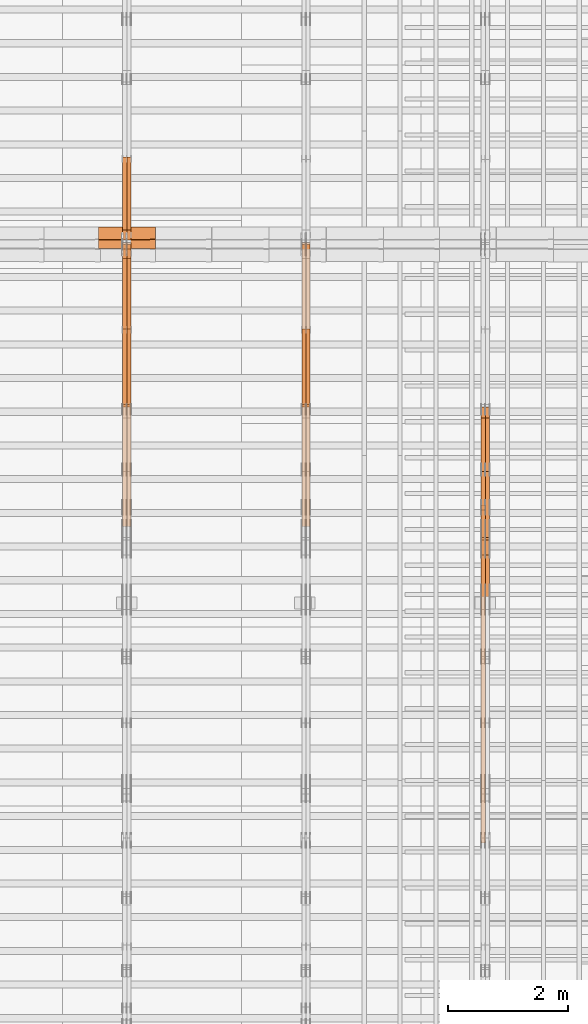
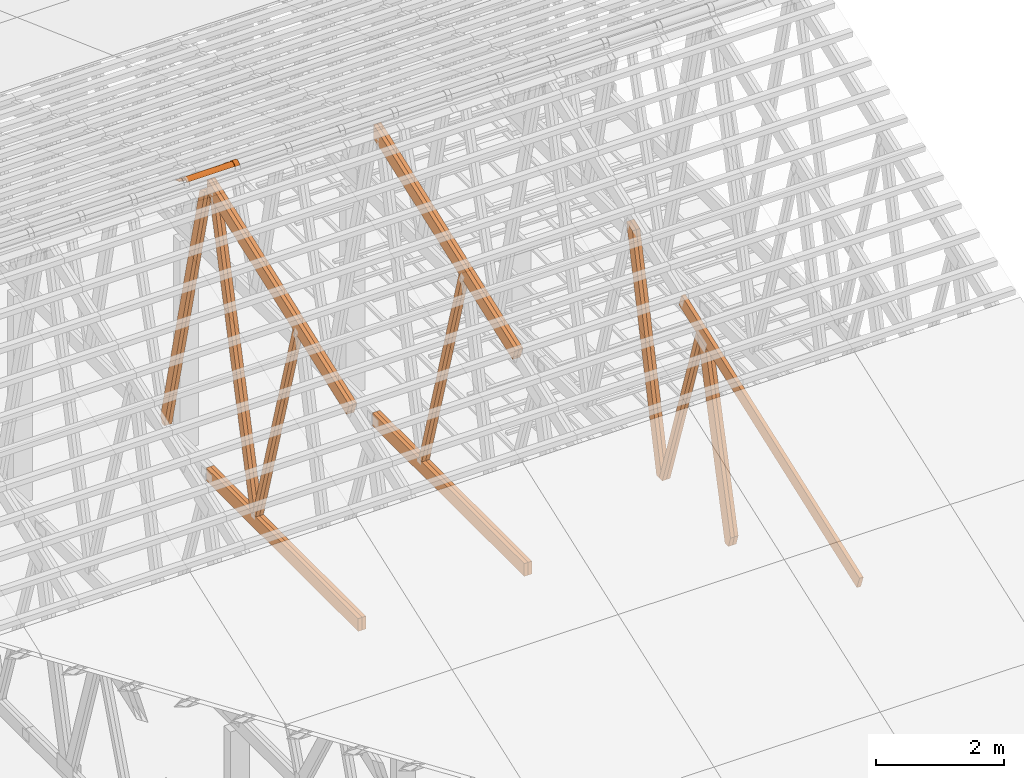
# One storey, part 52 of 189: 24 proxies.
"""IFC2X3 building model written with IfcOpenShell, lengths in millimetres."""

import ifcopenshell
import ifcopenshell.guid

model = None  # the IFC model being written
_history = None  # IfcOwnerHistory: only IFC2X3 demands one
_inside = {}  # id of a spatial element -> (the spatial element, [elements in it])
_under = {}  # id of a project, library or spatial element -> (it, [spatial elements below it])
_declared = {}  # id of a project -> (the project, [libraries it declares])
_typed = {}  # id of a type object -> (the type object, [elements of that type])
_made_of = {}  # id of a material, layer set ... -> (it, [elements and type objects made of it])


def new_model(schema):
    """Start an empty IFC model of exactly this schema.

    Asked for "IFC4X3", IfcOpenShell would pick the latest addendum, in which some entities
    have other attributes; the version numbers below select the first issue.
    IFC2X3 requires an IfcOwnerHistory on every rooted entity: one is made here for all.
    """
    global model, _history
    if schema == "IFC4X3":
        model = ifcopenshell.file(schema_version=(4, 3, 0, 0))
    else:
        model = ifcopenshell.file(schema=schema)
    _inside.clear()
    _under.clear()
    _declared.clear()
    _typed.clear()
    _made_of.clear()
    _history = None
    if model.schema == "IFC2X3":
        org = make("IfcOrganization", Name="unknown")
        user = make(
            "IfcPersonAndOrganization",
            ThePerson=make("IfcPerson", FamilyName="unknown"),
            TheOrganization=org,
        )
        app = make(
            "IfcApplication",
            ApplicationDeveloper=org,
            Version="unknown",
            ApplicationFullName="unknown",
            ApplicationIdentifier="unknown",
        )
        _history = make(
            "IfcOwnerHistory",
            OwningUser=user,
            OwningApplication=app,
            ChangeAction="ADDED",
            CreationDate=0,
        )
    return model


def make(cls, **values):
    """One entity of the class cls with the attributes given. An attribute that is None is left unset."""
    return model.create_entity(
        cls, **{name: value for name, value in values.items() if value is not None}
    )


def entity(cls, *values):
    """Any entity or typed value of the class cls, its attributes in the order of the schema. None: left unset."""
    e = model.create_entity(cls)
    for i, value in enumerate(values):
        if value is not None:
            e[i] = value
    return e


def rooted(cls, **values):
    """An entity with a GlobalId (a new one), such as an element, a storey or a relation."""
    return make(cls, GlobalId=ifcopenshell.guid.new(), OwnerHistory=_history, **values)


def si_unit(unit_type, name, prefix=None):
    """IfcSIUnit, for example si_unit("LENGTHUNIT", "METRE", prefix="MILLI")."""
    return make("IfcSIUnit", UnitType=unit_type, Prefix=prefix, Name=name)


def converted_unit(unit_type, name, factor, base, dimensions=None, offset=None):
    """IfcConversionBasedUnit, such as the inch: factor (a typed value) times the base unit."""
    return make(
        "IfcConversionBasedUnit"
        if offset is None
        else "IfcConversionBasedUnitWithOffset",
        ConversionOffset=offset,
        Dimensions=None
        if dimensions is None
        else entity("IfcDimensionalExponents", *dimensions),
        UnitType=unit_type,
        Name=name,
        ConversionFactor=make(
            "IfcMeasureWithUnit", ValueComponent=factor, UnitComponent=base
        ),
    )


def derived_unit(unit_type, elements):
    """IfcDerivedUnit: a product of units, each with its exponent."""
    return make(
        "IfcDerivedUnit",
        Elements=[
            make("IfcDerivedUnitElement", Unit=unit, Exponent=power)
            for unit, power in elements
        ],
        UnitType=unit_type,
    )


def assignment(units):
    """IfcUnitAssignment: the units of a project."""
    return None if units is None else make("IfcUnitAssignment", Units=units)


def point(xyz):
    """IfcCartesianPoint."""
    return None if xyz is None else make("IfcCartesianPoint", Coordinates=xyz)


def direction(xyz):
    """IfcDirection."""
    return None if xyz is None else make("IfcDirection", DirectionRatios=xyz)


def frame(location, z_axis=None, x_axis=None):
    """IfcAxis2Placement3D, a coordinate frame: its origin and axes. An axis left out is left unset."""
    return make(
        "IfcAxis2Placement3D",
        Location=point(location),
        Axis=direction(z_axis),
        RefDirection=direction(x_axis),
    )


def frame_2d(location, x_axis=None):
    """IfcAxis2Placement2D, a coordinate frame in the plane: its origin and x axis."""
    return make(
        "IfcAxis2Placement2D", Location=point(location), RefDirection=direction(x_axis)
    )


def origin():
    """The frame at (0, 0, 0) with its axes left unset."""
    return frame((0.0, 0.0, 0.0))


def origin_2d_with_axis():
    """The frame at (0, 0) in the plane with the x axis (1, 0) written out."""
    return frame_2d((0.0, 0.0), x_axis=(1.0, 0.0))


def place(relative_to, where):
    """IfcLocalPlacement: puts the frame where relative to a parent placement (None: the world)."""
    return make(
        "IfcLocalPlacement", PlacementRelTo=relative_to, RelativePlacement=where
    )


def context(
    kind, dimensions, precision=None, world=None, true_north=None, identifier=None
):
    """IfcGeometricRepresentationContext, for example the 3D "Model" context."""
    return make(
        "IfcGeometricRepresentationContext",
        ContextIdentifier=identifier,
        ContextType=kind,
        CoordinateSpaceDimension=dimensions,
        Precision=precision,
        WorldCoordinateSystem=world,
        TrueNorth=true_north,
    )


def subcontext(parent, identifier, kind, view, scale=None):
    """IfcGeometricRepresentationSubContext, for example "Body" below "Model"."""
    return make(
        "IfcGeometricRepresentationSubContext",
        ContextIdentifier=identifier,
        ContextType=kind,
        ParentContext=parent,
        TargetScale=scale,
        TargetView=view,
    )


def project(units=None, contexts=None):
    """IfcProject with its units and contexts."""
    return rooted(
        "IfcProject",
        Name="project",
        RepresentationContexts=contexts,
        UnitsInContext=assignment(units),
    )


def spatial(cls, under=None, at=None, **own):
    """A site, building, storey or space (cls), placed at a placement, below another one or the project."""
    s = rooted(cls, ObjectPlacement=at, **own)
    if under is not None:
        _under.setdefault(under.id(), (under, []))[1].append(s)
    return s


def polyline(points):
    """IfcPolyline through the points."""
    return make("IfcPolyline", Points=[point(p) for p in points])


def circle_curve(where, radius):
    """IfcCircle in the frame where."""
    return make("IfcCircle", Position=where, Radius=radius)


def parameter(value):
    """IfcParameterValue: where a trimmed curve begins or ends, as a parameter of its basis curve."""
    return model.create_entity("IfcParameterValue", value)


def trimmed(basis, trim1, trim2, sense, master):
    """IfcTrimmedCurve: the piece of a basis curve between two trims."""
    return make(
        "IfcTrimmedCurve",
        BasisCurve=basis,
        Trim1=trim1,
        Trim2=trim2,
        SenseAgreement=sense,
        MasterRepresentation=master,
    )


def segment(curve, same_sense, transition):
    """IfcCompositeCurveSegment."""
    return make(
        "IfcCompositeCurveSegment",
        Transition=transition,
        SameSense=same_sense,
        ParentCurve=curve,
    )


def composite_curve(segments, self_intersect=None):
    """IfcCompositeCurve: segments joined end to end."""
    return make("IfcCompositeCurve", Segments=segments, SelfIntersect=self_intersect)


def profile(cls, at=None, kind="AREA", **sizes):
    """A parametric profile (cls). Its sizes go by their IFC names, for example OverallWidth=200.0."""
    return make(cls, ProfileType=kind, Position=at, **sizes)


def rectangle(**sizes):
    """IfcRectangleProfileDef."""
    return profile("IfcRectangleProfileDef", **sizes)


def outline(outer, holes=None, kind="AREA"):
    """IfcArbitraryClosedProfileDef: a profile drawn as a closed curve; with holes, ...WithVoids."""
    if holes is None:
        return make("IfcArbitraryClosedProfileDef", ProfileType=kind, OuterCurve=outer)
    return make(
        "IfcArbitraryProfileDefWithVoids",
        ProfileType=kind,
        OuterCurve=outer,
        InnerCurves=holes,
    )


def extrude(swept, where, along, depth):
    """IfcExtrudedAreaSolid: the profile swept, set in the frame where, extruded along a direction by depth."""
    return make(
        "IfcExtrudedAreaSolid",
        SweptArea=swept,
        Position=where,
        ExtrudedDirection=direction(along),
        Depth=depth,
    )


def shape(context_of_items, identifier, shape_type, items):
    """IfcShapeRepresentation: the items that make up one representation, for example the "Body"."""
    return make(
        "IfcShapeRepresentation",
        ContextOfItems=context_of_items,
        RepresentationIdentifier=identifier,
        RepresentationType=shape_type,
        Items=items,
    )


def source(mapping_origin, context_of_items, identifier, shape_type, items):
    """IfcRepresentationMap: a shape defined once, which mapped items show again and again."""
    return make(
        "IfcRepresentationMap",
        MappingOrigin=mapping_origin,
        MappedRepresentation=shape(context_of_items, identifier, shape_type, items),
    )


def transform(
    local_origin,
    x_axis=None,
    y_axis=None,
    z_axis=None,
    scale=None,
    scale2=None,
    scale3=None,
    uniform=True,
):
    """IfcCartesianTransformationOperator3D, or its non-uniform kind. x_axis, y_axis, z_axis: its Axis1, 2, 3."""
    if uniform:
        return make(
            "IfcCartesianTransformationOperator3D",
            Axis1=direction(x_axis),
            Axis2=direction(y_axis),
            LocalOrigin=point(local_origin),
            Scale=scale,
            Axis3=direction(z_axis),
        )
    return make(
        "IfcCartesianTransformationOperator3DnonUniform",
        Axis1=direction(x_axis),
        Axis2=direction(y_axis),
        LocalOrigin=point(local_origin),
        Scale=scale,
        Axis3=direction(z_axis),
        Scale2=scale2,
        Scale3=scale3,
    )


def mapped(mapping_source, mapping_target):
    """IfcMappedItem: shows the shape of a source again, moved by a transform."""
    return make(
        "IfcMappedItem", MappingSource=mapping_source, MappingTarget=mapping_target
    )


def material(Name=None, Category=None):
    """IfcMaterial."""
    return make("IfcMaterial", Name=Name, Category=Category)


def made_of(thing, what):
    """Note that an element or type object is made of a material, layer set ...; save() writes the relation."""
    if what is not None:
        _made_of.setdefault(what.id(), (what, []))[1].append(thing)
    return thing


def type_object(cls, material=None, **own):
    """A type object (cls), such as IfcWallType, which elements share."""
    return made_of(rooted(cls, **own), material)


def type_shapes(of_type, sources):
    """Give a type object the sources (RepresentationMaps) that its elements show as mapped items."""
    of_type.RepresentationMaps = sources


def element(
    cls,
    number,
    at=None,
    inside=None,
    cuts=None,
    type_object=None,
    material=None,
    context=None,
    identifier="Body",
    shape_type=None,
    held_by="IfcProductDefinitionShape",
    body=None,
    shapes=None,
    **own,
):
    """One element of the class cls, such as IfcWall. Its Tag is "e" and its number.

    at: its placement. inside: the storey or other place that contains it. cuts: it is an
    opening in that element (IfcRelVoidsElement). A single representation is given by context,
    identifier, shape_type and body (its items); several are given by shapes. held_by: the class
    of the entity that holds the representations. save() writes the other relations.
    """
    e = rooted(cls, Tag="e%d" % number, ObjectPlacement=at, **own)
    if body is not None:
        shapes = [shape(context, identifier, shape_type, body)]
    if shapes is not None:
        e.Representation = make(held_by, Representations=shapes)
    if inside is not None:
        _inside.setdefault(inside.id(), (inside, []))[1].append(e)
    if cuts is not None:
        rooted(
            "IfcRelVoidsElement", RelatingBuildingElement=cuts, RelatedOpeningElement=e
        )
    if type_object is not None:
        _typed.setdefault(type_object.id(), (type_object, []))[1].append(e)
    return made_of(e, material)


def aggregate(whole, parts):
    """IfcRelAggregates: a whole, such as a stair, and the parts it consists of."""
    return rooted("IfcRelAggregates", RelatingObject=whole, RelatedObjects=parts)


def save(model, path):
    """Write the relations noted so far, then the file.

    IfcRelAggregates (storeys below a building ...), IfcRelContainedInSpatialStructure (elements
    in a storey), IfcRelDefinesByType, IfcRelAssociatesMaterial and IfcRelDeclares: one each for
    every whole, place, type object, material and project.
    """
    for whole, parts in _under.values():
        aggregate(whole, parts)
    for where, things in _inside.values():
        rooted(
            "IfcRelContainedInSpatialStructure",
            RelatedElements=things,
            RelatingStructure=where,
        )
    for kind, things in _typed.values():
        rooted("IfcRelDefinesByType", RelatedObjects=things, RelatingType=kind)
    for what, things in _made_of.values():
        rooted("IfcRelAssociatesMaterial", RelatedObjects=things, RelatingMaterial=what)
    for by, libraries in _declared.values():
        rooted("IfcRelDeclares", RelatingContext=by, RelatedDefinitions=libraries)
    model.write(path)


model = new_model("IFC2X3")

# Units and contexts
model_context = context("Model", 3, precision=0.01, world=origin(), true_north=direction((6.12303176911189e-17, 1.0)))
body_context = subcontext(model_context, "Body", "Model", "MODEL_VIEW")
ifc_project = project(units=[si_unit("LENGTHUNIT", "METRE", prefix="MILLI"), si_unit("AREAUNIT", "SQUARE_METRE"), si_unit("VOLUMEUNIT", "CUBIC_METRE"), converted_unit("PLANEANGLEUNIT", "DEGREE", entity("IfcRatioMeasure", 0.0174532925199433), si_unit("PLANEANGLEUNIT", "RADIAN"), dimensions=[0, 0, 0, 0, 0, 0, 0]), si_unit("MASSUNIT", "GRAM", prefix="KILO"), derived_unit("MASSDENSITYUNIT", [(si_unit("MASSUNIT", "GRAM", prefix="KILO"), 1), (si_unit("LENGTHUNIT", "METRE"), -3)]), si_unit("TIMEUNIT", "SECOND"), si_unit("FREQUENCYUNIT", "HERTZ"), si_unit("THERMODYNAMICTEMPERATUREUNIT", "DEGREE_CELSIUS"), derived_unit("THERMALTRANSMITTANCEUNIT", [(si_unit("MASSUNIT", "GRAM", prefix="KILO"), 1), (si_unit("THERMODYNAMICTEMPERATUREUNIT", "KELVIN"), -1), (si_unit("TIMEUNIT", "SECOND"), -3)]), derived_unit("VOLUMETRICFLOWRATEUNIT", [(si_unit("LENGTHUNIT", "METRE"), 3), (si_unit("TIMEUNIT", "SECOND"), -1)]), si_unit("ELECTRICCURRENTUNIT", "AMPERE"), si_unit("ELECTRICVOLTAGEUNIT", "VOLT"), si_unit("POWERUNIT", "WATT"), si_unit("FORCEUNIT", "NEWTON"), si_unit("ILLUMINANCEUNIT", "LUX"), si_unit("LUMINOUSFLUXUNIT", "LUMEN"), si_unit("LUMINOUSINTENSITYUNIT", "CANDELA"), derived_unit("USERDEFINED", [(si_unit("MASSUNIT", "GRAM", prefix="KILO"), -1), (si_unit("LENGTHUNIT", "METRE"), -2), (si_unit("TIMEUNIT", "SECOND"), 3), (si_unit("LUMINOUSFLUXUNIT", "LUMEN"), 1)]), derived_unit("LINEARVELOCITYUNIT", [(si_unit("LENGTHUNIT", "METRE"), 1), (si_unit("TIMEUNIT", "SECOND"), -1)]), si_unit("PRESSUREUNIT", "PASCAL"), derived_unit("USERDEFINED", [(si_unit("LENGTHUNIT", "METRE"), -2), (si_unit("MASSUNIT", "GRAM", prefix="KILO"), 1), (si_unit("TIMEUNIT", "SECOND"), -2)])], contexts=[model_context])

# Site, building, storey
site_placement = place(None, origin())
site = spatial("IfcSite", under=ifc_project, at=site_placement, CompositionType="ELEMENT")
building_placement = place(site_placement, origin())
building = spatial("IfcBuilding", under=site, at=building_placement, CompositionType="ELEMENT")
storey_placement = place(building_placement, origin())
storey = spatial("IfcBuildingStorey", under=building, at=storey_placement, Name="Default", CompositionType="ELEMENT", Elevation=0.0)

# Proxies
ifc_material_1 = material(Name="IfcSurfaceStyle #241796")
building_element_proxy_type_1 = type_object("IfcBuildingElementProxyType", Name="T1-W3 241794", PredefinedType="NOTDEFINED", material=ifc_material_1)
shared_shape_1 = source(origin(), body_context, "Body", "SweptSolid", [
    extrude(outline(polyline([(-2625.55080717397, -84.9998286237256), (1749.48871563991, -84.9998286237256), (1768.20584427244, 0.000602085469291858), (1625.445846867, 85.0000405971208), (-2517.58959960538, 84.9990145648612), (-2625.55080717397, -84.9998286237256)])), frame((1768.20584427244, 85.0000405971208, 0.0), z_axis=(0.0, 0.0, 1.0), x_axis=(-1.0, 0.0, 0.0)), (0.0, 0.0, 1.0), 69.9999999999997),
])
type_shapes(building_element_proxy_type_1, [shared_shape_1])
proxy_1_placement = place(building_placement, frame((45300.0, 10918.6728403286, 263.278932236374), z_axis=(-1.0, 0.0, 0.0), x_axis=(0.0, 0.215047682154604, 0.976603550269982)))
element("IfcBuildingElementProxy", 1, at=proxy_1_placement, inside=storey, type_object=building_element_proxy_type_1, material=ifc_material_1, Name="T1-W3", context=body_context, shape_type="MappedRepresentation", body=[
    mapped(shared_shape_1, transform((0.0, 0.0, 0.0), scale=1.0)),
])
ifc_material_2 = material(Name="IfcSurfaceStyle #241730")
building_element_proxy_type_2 = type_object("IfcBuildingElementProxyType", Name="T1-W3 241728", PredefinedType="NOTDEFINED", material=ifc_material_2)
shared_shape_2 = source(origin(), body_context, "Body", "SweptSolid", [
    extrude(outline(polyline([(-2625.55080717397, -84.9998286237256), (1749.48871563991, -84.9998286237256), (1768.20584427244, 0.000602085469291858), (1625.445846867, 85.0000405971208), (-2517.58959960538, 84.9990145648612), (-2625.55080717397, -84.9998286237256)])), frame((1768.20584427244, 85.0000405971208, 0.0), z_axis=(0.0, 0.0, 1.0), x_axis=(-1.0, 0.0, 0.0)), (0.0, 0.0, 1.0), 69.9999999999997),
])
type_shapes(building_element_proxy_type_2, [shared_shape_2])
proxy_2_placement = place(building_placement, frame((45230.0, 10918.6728403286, 263.278932236374), z_axis=(-1.0, 0.0, 0.0), x_axis=(0.0, 0.215047682154604, 0.976603550269982)))
element("IfcBuildingElementProxy", 2, at=proxy_2_placement, inside=storey, type_object=building_element_proxy_type_2, material=ifc_material_2, Name="T1-W3", context=body_context, shape_type="MappedRepresentation", body=[
    mapped(shared_shape_2, transform((0.0, 0.0, 0.0), scale=1.0)),
])
ifc_material_3 = material(Name="IfcSurfaceStyle #241532")
building_element_proxy_type_3 = type_object("IfcBuildingElementProxyType", Name="T1-W7 241530", PredefinedType="NOTDEFINED", material=ifc_material_3)
shared_shape_3 = source(origin(), body_context, "Body", "SweptSolid", [
    extrude(outline(polyline([(-2158.15323194511, -47.5001976605119), (1398.58481981178, -47.5001976605119), (1473.93376219819, -0.000131511554346808), (1475.30069254941, 47.5002634162891), (-2189.66604261427, 47.5002634162891), (-2158.15323194511, -47.5001976605119)])), frame((1475.30069254941, 47.5002634162891, 0.0), z_axis=(0.0, 0.0, 1.0), x_axis=(-1.0, 0.0, 0.0)), (0.0, 0.0, 1.0), 69.9999999999998),
])
type_shapes(building_element_proxy_type_3, [shared_shape_3])
proxy_3_placement = place(building_placement, frame((45300.0, 9847.787109375, 3723.57788085937), z_axis=(-1.0, 0.0, 0.0), x_axis=(0.0, 0.314845237923105, -0.949143021971475)))
element("IfcBuildingElementProxy", 3, at=proxy_3_placement, inside=storey, type_object=building_element_proxy_type_3, material=ifc_material_3, Name="T1-W7", context=body_context, shape_type="MappedRepresentation", body=[
    mapped(shared_shape_3, transform((0.0, 0.0, 0.0), scale=1.0)),
])
ifc_material_4 = material(Name="IfcSurfaceStyle #241466")
building_element_proxy_type_4 = type_object("IfcBuildingElementProxyType", Name="T1-W7 241464", PredefinedType="NOTDEFINED", material=ifc_material_4)
shared_shape_4 = source(origin(), body_context, "Body", "SweptSolid", [
    extrude(outline(polyline([(-2158.15323194511, -47.5001976605119), (1398.58481981178, -47.5001976605119), (1473.93376219819, -0.000131511554346808), (1475.30069254941, 47.5002634162891), (-2189.66604261427, 47.5002634162891), (-2158.15323194511, -47.5001976605119)])), frame((1475.30069254941, 47.5002634162891, 0.0), z_axis=(0.0, 0.0, 1.0), x_axis=(-1.0, 0.0, 0.0)), (0.0, 0.0, 1.0), 69.9999999999998),
])
type_shapes(building_element_proxy_type_4, [shared_shape_4])
proxy_4_placement = place(building_placement, frame((45230.0, 9847.787109375, 3723.57788085937), z_axis=(-1.0, 0.0, 0.0), x_axis=(0.0, 0.314845237923105, -0.949143021971475)))
element("IfcBuildingElementProxy", 4, at=proxy_4_placement, inside=storey, type_object=building_element_proxy_type_4, material=ifc_material_4, Name="T1-W7", context=body_context, shape_type="MappedRepresentation", body=[
    mapped(shared_shape_4, transform((0.0, 0.0, 0.0), scale=1.0)),
])
ifc_material_5 = material(Name="IfcSurfaceStyle #241268")
building_element_proxy_type_5 = type_object("IfcBuildingElementProxyType", Name="T1-W1 241266", PredefinedType="NOTDEFINED", material=ifc_material_5)
shared_shape_5 = source(origin(), body_context, "Body", "SweptSolid", [
    extrude(outline(polyline([(-2144.69382208629, -109.99948311278), (1421.70798092021, -109.99948311278), (1448.88116133745, -0.000392715405943322), (1271.09900468242, 109.999679470483), (-1996.99432485378, 109.999679470483), (-2144.69382208629, -109.99948311278)])), frame((1448.88130194731, 110.000176487146, 0.0), z_axis=(0.0, 0.0, 1.0), x_axis=(-1.0, 0.0, 0.0)), (0.0, 0.0, 1.0), 69.9999999999998),
])
type_shapes(building_element_proxy_type_5, [shared_shape_5])
proxy_5_placement = place(building_placement, frame((45300.0, 8727.74270166583, 271.380182391418), z_axis=(-1.0, 0.0, 0.0), x_axis=(0.0, 0.239819839925978, 0.970817410421691)))
element("IfcBuildingElementProxy", 5, at=proxy_5_placement, inside=storey, type_object=building_element_proxy_type_5, material=ifc_material_5, Name="T1-W1", context=body_context, shape_type="MappedRepresentation", body=[
    mapped(shared_shape_5, transform((0.0, 0.0, 0.0), scale=1.0)),
])
ifc_material_6 = material(Name="IfcSurfaceStyle #241202")
building_element_proxy_type_6 = type_object("IfcBuildingElementProxyType", Name="T1-W1 241200", PredefinedType="NOTDEFINED", material=ifc_material_6)
shared_shape_6 = source(origin(), body_context, "Body", "SweptSolid", [
    extrude(outline(polyline([(-2144.69382208629, -109.99948311278), (1421.70798092021, -109.99948311278), (1448.88116133745, -0.000392715405943322), (1271.09900468242, 109.999679470483), (-1996.99432485378, 109.999679470483), (-2144.69382208629, -109.99948311278)])), frame((1448.88130194731, 110.000176487146, 0.0), z_axis=(0.0, 0.0, 1.0), x_axis=(-1.0, 0.0, 0.0)), (0.0, 0.0, 1.0), 69.9999999999998),
])
type_shapes(building_element_proxy_type_6, [shared_shape_6])
proxy_6_placement = place(building_placement, frame((45230.0, 8727.74270166583, 271.380182391418), z_axis=(-1.0, 0.0, 0.0), x_axis=(0.0, 0.239819839925978, 0.970817410421691)))
element("IfcBuildingElementProxy", 6, at=proxy_6_placement, inside=storey, type_object=building_element_proxy_type_6, material=ifc_material_6, Name="T1-W1", context=body_context, shape_type="MappedRepresentation", body=[
    mapped(shared_shape_6, transform((0.0, 0.0, 0.0), scale=1.0)),
])
ifc_material_7 = material(Name="IfcSurfaceStyle #237509")
building_element_proxy_type_7 = type_object("IfcBuildingElementProxyType", Name="T1-T1 237507", PredefinedType="NOTDEFINED", material=ifc_material_7)
shared_shape_7 = source(origin(), body_context, "Body", "SweptSolid", [
    extrude(outline(polyline([(-2964.99981923522, -122.500027388895), (2964.99982426074, -122.500027388895), (2964.99984011048, 122.500027388895), (-2964.99984513599, 122.500027388895), (-2964.99981923522, -122.500027388895)])), frame((2965.00021857317, 122.500056320695, 0.0), z_axis=(0.0, 0.0, 1.0), x_axis=(-1.0, 0.0, 0.0)), (0.0, 0.0, 1.0), 69.9999999999996),
])
type_shapes(building_element_proxy_type_7, [shared_shape_7])
proxy_7_placement = place(building_placement, frame((45230.0, 10391.0374749089, 3921.30478975487), z_axis=(-1.0, 0.0, 0.0), x_axis=(0.0, -0.939692620785908, -0.342020143325669)))
element("IfcBuildingElementProxy", 7, at=proxy_7_placement, inside=storey, type_object=building_element_proxy_type_7, material=ifc_material_7, Name="T1-T1", context=body_context, shape_type="MappedRepresentation", body=[
    mapped(shared_shape_7, transform((0.0, 0.0, 0.0), scale=1.0)),
])
ifc_material_8 = material(Name="IfcSurfaceStyle #226270")
building_element_proxy_type_8 = type_object("IfcBuildingElementProxyType", Name="T1-W6 226268", PredefinedType="NOTDEFINED", material=ifc_material_8)
shared_shape_8 = source(origin(), body_context, "Body", "SweptSolid", [
    extrude(outline(polyline([(-2640.84340836012, -47.4996765865792), (1711.12245024294, -47.4996765865792), (1797.68490303083, -9.57690019346202e-05), (1800.72595169379, 47.4997244710801), (-2668.68989660745, 47.4997244710801), (-2640.84340836012, -47.4996765865792)])), frame((1800.72595169379, 47.5003009358159, 0.0), z_axis=(0.0, 0.0, 1.0), x_axis=(-1.0, 0.0, 0.0)), (0.0, 0.0, 1.0), 69.9999999999997),
])
type_shapes(building_element_proxy_type_8, [shared_shape_8])
proxy_8_placement = place(building_placement, frame((42300.0, 12074.2896156894, 4533.9586582452), z_axis=(-1.0, 0.0, 0.0), x_axis=(0.0, 0.28128598310461, -0.959623986626467)))
element("IfcBuildingElementProxy", 8, at=proxy_8_placement, inside=storey, type_object=building_element_proxy_type_8, material=ifc_material_8, Name="T1-W6", context=body_context, shape_type="MappedRepresentation", body=[
    mapped(shared_shape_8, transform((0.0, 0.0, 0.0), scale=1.0)),
])
ifc_material_9 = material(Name="IfcSurfaceStyle #226204")
building_element_proxy_type_9 = type_object("IfcBuildingElementProxyType", Name="T1-W6 226202", PredefinedType="NOTDEFINED", material=ifc_material_9)
shared_shape_9 = source(origin(), body_context, "Body", "SweptSolid", [
    extrude(outline(polyline([(-2640.84340836012, -47.4996765865792), (1711.12245024294, -47.4996765865792), (1797.68490303083, -9.57690019346202e-05), (1800.72595169379, 47.4997244710801), (-2668.68989660745, 47.4997244710801), (-2640.84340836012, -47.4996765865792)])), frame((1800.72595169379, 47.5003009358159, 0.0), z_axis=(0.0, 0.0, 1.0), x_axis=(-1.0, 0.0, 0.0)), (0.0, 0.0, 1.0), 69.9999999999997),
])
type_shapes(building_element_proxy_type_9, [shared_shape_9])
proxy_9_placement = place(building_placement, frame((42230.0, 12074.2896156894, 4533.9586582452), z_axis=(-1.0, 0.0, 0.0), x_axis=(0.0, 0.28128598310461, -0.959623986626467)))
element("IfcBuildingElementProxy", 9, at=proxy_9_placement, inside=storey, type_object=building_element_proxy_type_9, material=ifc_material_9, Name="T1-W6", context=body_context, shape_type="MappedRepresentation", body=[
    mapped(shared_shape_9, transform((0.0, 0.0, 0.0), scale=1.0)),
])
ifc_material_10 = material(Name="IfcSurfaceStyle #222250")
building_element_proxy_type_10 = type_object("IfcBuildingElementProxyType", Name="T1-B3 222248", PredefinedType="NOTDEFINED", material=ifc_material_10)
shared_shape_10 = source(origin(), body_context, "Body", "SweptSolid", [
    extrude(rectangle(XDim=4751.0283203125, YDim=245.000000000001, at=origin_2d_with_axis()), frame((2375.51416015625, 122.5, 0.0), z_axis=(0.0, 0.0, 1.0), x_axis=(-1.0, 0.0, 0.0)), (0.0, 0.0, 1.0), 69.9999999999997),
])
type_shapes(building_element_proxy_type_10, [shared_shape_10])
proxy_10_placement = place(building_placement, frame((42300.0, 10029.23046875, 245.0), z_axis=(-1.0, 0.0, 0.0), x_axis=(0.0, 1.0, 0.0)))
element("IfcBuildingElementProxy", 10, at=proxy_10_placement, inside=storey, type_object=building_element_proxy_type_10, material=ifc_material_10, Name="T1-B3", context=body_context, shape_type="MappedRepresentation", body=[
    mapped(shared_shape_10, transform((0.0, 0.0, 0.0), scale=1.0)),
])
ifc_material_11 = material(Name="IfcSurfaceStyle #222193")
building_element_proxy_type_11 = type_object("IfcBuildingElementProxyType", Name="T1-B3 222191", PredefinedType="NOTDEFINED", material=ifc_material_11)
shared_shape_11 = source(origin(), body_context, "Body", "SweptSolid", [
    extrude(rectangle(XDim=4751.0283203125, YDim=245.000000000001, at=origin_2d_with_axis()), frame((2375.51416015625, 122.5, 0.0), z_axis=(0.0, 0.0, 1.0), x_axis=(-1.0, 0.0, 0.0)), (0.0, 0.0, 1.0), 69.9999999999997),
])
type_shapes(building_element_proxy_type_11, [shared_shape_11])
proxy_11_placement = place(building_placement, frame((42230.0, 10029.23046875, 245.0), z_axis=(-1.0, 0.0, 0.0), x_axis=(0.0, 1.0, 0.0)))
element("IfcBuildingElementProxy", 11, at=proxy_11_placement, inside=storey, type_object=building_element_proxy_type_11, material=ifc_material_11, Name="T1-B3", context=body_context, shape_type="MappedRepresentation", body=[
    mapped(shared_shape_11, transform((0.0, 0.0, 0.0), scale=1.0)),
])
ifc_material_12 = material(Name="IfcSurfaceStyle #221662")
building_element_proxy_type_12 = type_object("IfcBuildingElementProxyType", Name="T1-T3 221660", PredefinedType="NOTDEFINED", material=ifc_material_12)
shared_shape_12 = source(origin(), body_context, "Body", "SweptSolid", [
    extrude(outline(polyline([(-2341.64890001385, -122.499972785692), (2386.23525922045, -122.499972785692), (2297.06252495753, 122.499972785692), (-2341.64888416412, 122.499972785692), (-2341.64890001385, -122.499972785692)])), frame((2386.23525922045, 122.499973888764, 0.0), z_axis=(0.0, 0.0, 1.0), x_axis=(-1.0, 0.0, 0.0)), (0.0, 0.0, 1.0), 69.9999999999997),
])
type_shapes(building_element_proxy_type_12, [shared_shape_12])
proxy_12_placement = place(building_placement, frame((42300.0, 14833.7949607394, 5538.33627266055), z_axis=(-1.0, 0.0, 0.0), x_axis=(0.0, -0.939692620785908, -0.342020143325669)))
element("IfcBuildingElementProxy", 12, at=proxy_12_placement, inside=storey, type_object=building_element_proxy_type_12, material=ifc_material_12, Name="T1-T3", context=body_context, shape_type="MappedRepresentation", body=[
    mapped(shared_shape_12, transform((0.0, 0.0, 0.0), scale=1.0)),
])
ifc_material_13 = material(Name="IfcSurfaceStyle #221605")
building_element_proxy_type_13 = type_object("IfcBuildingElementProxyType", Name="T1-T3 221603", PredefinedType="NOTDEFINED", material=ifc_material_13)
shared_shape_13 = source(origin(), body_context, "Body", "SweptSolid", [
    extrude(outline(polyline([(-2341.64890001385, -122.499972785692), (2386.23525922045, -122.499972785692), (2297.06252495753, 122.499972785692), (-2341.64888416412, 122.499972785692), (-2341.64890001385, -122.499972785692)])), frame((2386.23525922045, 122.499973888764, 0.0), z_axis=(0.0, 0.0, 1.0), x_axis=(-1.0, 0.0, 0.0)), (0.0, 0.0, 1.0), 69.9999999999997),
])
type_shapes(building_element_proxy_type_13, [shared_shape_13])
proxy_13_placement = place(building_placement, frame((42230.0, 14833.7949607394, 5538.33627266055), z_axis=(-1.0, 0.0, 0.0), x_axis=(0.0, -0.939692620785908, -0.342020143325669)))
element("IfcBuildingElementProxy", 13, at=proxy_13_placement, inside=storey, type_object=building_element_proxy_type_13, material=ifc_material_13, Name="T1-T3", context=body_context, shape_type="MappedRepresentation", body=[
    mapped(shared_shape_13, transform((0.0, 0.0, 0.0), scale=1.0)),
])
ifc_material_14 = material(Name="IfcSurfaceStyle #210744")
building_element_proxy_type_14 = type_object("IfcBuildingElementProxyType", Name="T1-W5 210742", PredefinedType="NOTDEFINED", material=ifc_material_14)
shared_shape_14 = source(origin(), body_context, "Body", "SweptSolid", [
    extrude(outline(polyline([(-3233.61216530572, -72.4999091305202), (2153.79187521892, -72.4999091305202), (2171.36968478227, -7.18521572819375e-05), (2045.62106208646, 72.4999450565989), (-3137.17045678193, 72.4999450565989), (-3233.61216530572, -72.4999091305202)])), frame((2171.36968478227, 72.500192121173, 0.0), z_axis=(0.0, 0.0, 1.0), x_axis=(-1.0, 0.0, 0.0)), (0.0, 0.0, 1.0), 69.9999999999997),
])
type_shapes(building_element_proxy_type_14, [shared_shape_14])
proxy_14_placement = place(building_placement, frame((39300.0, 13261.0146935344, 262.082919891325), z_axis=(-1.0, 0.0, 0.0), x_axis=(0.0, 0.235625623344066, 0.97184389982328)))
element("IfcBuildingElementProxy", 14, at=proxy_14_placement, inside=storey, type_object=building_element_proxy_type_14, material=ifc_material_14, Name="T1-W5", context=body_context, shape_type="MappedRepresentation", body=[
    mapped(shared_shape_14, transform((0.0, 0.0, 0.0), scale=1.0)),
])
ifc_material_15 = material(Name="IfcSurfaceStyle #210678")
building_element_proxy_type_15 = type_object("IfcBuildingElementProxyType", Name="T1-W5 210676", PredefinedType="NOTDEFINED", material=ifc_material_15)
shared_shape_15 = source(origin(), body_context, "Body", "SweptSolid", [
    extrude(outline(polyline([(-3233.61216530572, -72.4999091305202), (2153.79187521892, -72.4999091305202), (2171.36968478227, -7.18521572819375e-05), (2045.62106208646, 72.4999450565989), (-3137.17045678193, 72.4999450565989), (-3233.61216530572, -72.4999091305202)])), frame((2171.36968478227, 72.500192121173, 0.0), z_axis=(0.0, 0.0, 1.0), x_axis=(-1.0, 0.0, 0.0)), (0.0, 0.0, 1.0), 69.9999999999997),
])
type_shapes(building_element_proxy_type_15, [shared_shape_15])
proxy_15_placement = place(building_placement, frame((39230.0, 13261.0146935344, 262.082919891325), z_axis=(-1.0, 0.0, 0.0), x_axis=(0.0, 0.235625623344066, 0.97184389982328)))
element("IfcBuildingElementProxy", 15, at=proxy_15_placement, inside=storey, type_object=building_element_proxy_type_15, material=ifc_material_15, Name="T1-W5", context=body_context, shape_type="MappedRepresentation", body=[
    mapped(shared_shape_15, transform((0.0, 0.0, 0.0), scale=1.0)),
])
ifc_material_16 = material(Name="IfcSurfaceStyle #210612")
building_element_proxy_type_16 = type_object("IfcBuildingElementProxyType", Name="T1-W5 210610", PredefinedType="NOTDEFINED", material=ifc_material_16)
shared_shape_16 = source(origin(), body_context, "Body", "SweptSolid", [
    extrude(outline(polyline([(-3137.17045678193, -72.5002081306407), (2045.62106208646, -72.5002081306408), (2171.36968478227, 5.58426931168476e-05), (2153.79187521892, 72.5001802092942), (-3233.61216530572, 72.5001802092942), (-3137.17045678193, -72.5002081306407)])), frame((2171.36968478227, 72.5001802092942, 0.0), z_axis=(0.0, 0.0, 1.0), x_axis=(-1.0, 0.0, 0.0)), (0.0, 0.0, 1.0), 69.9999999999997),
])
type_shapes(building_element_proxy_type_16, [shared_shape_16])
proxy_16_placement = place(building_placement, frame((39300.0, 16098.0675635854, 227.917113003597), z_axis=(-1.0, 0.0, 0.0), x_axis=(0.0, -0.235625623344066, 0.971843899823279)))
element("IfcBuildingElementProxy", 16, at=proxy_16_placement, inside=storey, type_object=building_element_proxy_type_16, material=ifc_material_16, Name="T1-W5", context=body_context, shape_type="MappedRepresentation", body=[
    mapped(shared_shape_16, transform((0.0, 0.0, 0.0), scale=1.0)),
])
ifc_material_17 = material(Name="IfcSurfaceStyle #210546")
building_element_proxy_type_17 = type_object("IfcBuildingElementProxyType", Name="T1-W5 210544", PredefinedType="NOTDEFINED", material=ifc_material_17)
shared_shape_17 = source(origin(), body_context, "Body", "SweptSolid", [
    extrude(outline(polyline([(-3137.17045678193, -72.5002081306407), (2045.62106208646, -72.5002081306408), (2171.36968478227, 5.58426931168476e-05), (2153.79187521892, 72.5001802092942), (-3233.61216530572, 72.5001802092942), (-3137.17045678193, -72.5002081306407)])), frame((2171.36968478227, 72.5001802092942, 0.0), z_axis=(0.0, 0.0, 1.0), x_axis=(-1.0, 0.0, 0.0)), (0.0, 0.0, 1.0), 69.9999999999997),
])
type_shapes(building_element_proxy_type_17, [shared_shape_17])
proxy_17_placement = place(building_placement, frame((39230.0, 16098.0675635854, 227.917113003597), z_axis=(-1.0, 0.0, 0.0), x_axis=(0.0, -0.235625623344066, 0.971843899823279)))
element("IfcBuildingElementProxy", 17, at=proxy_17_placement, inside=storey, type_object=building_element_proxy_type_17, material=ifc_material_17, Name="T1-W5", context=body_context, shape_type="MappedRepresentation", body=[
    mapped(shared_shape_17, transform((0.0, 0.0, 0.0), scale=1.0)),
])
ifc_material_18 = material(Name="IfcSurfaceStyle #210480")
building_element_proxy_type_18 = type_object("IfcBuildingElementProxyType", Name="T1-W6 210478", PredefinedType="NOTDEFINED", material=ifc_material_18)
shared_shape_18 = source(origin(), body_context, "Body", "SweptSolid", [
    extrude(outline(polyline([(-2640.84340836012, -47.4996765865792), (1711.12245024294, -47.4996765865792), (1797.68490303083, -9.57690019346202e-05), (1800.72595169379, 47.4997244710801), (-2668.68989660745, 47.4997244710801), (-2640.84340836012, -47.4996765865792)])), frame((1800.72595169379, 47.5003009358159, 0.0), z_axis=(0.0, 0.0, 1.0), x_axis=(-1.0, 0.0, 0.0)), (0.0, 0.0, 1.0), 69.9999999999997),
])
type_shapes(building_element_proxy_type_18, [shared_shape_18])
proxy_18_placement = place(building_placement, frame((39300.0, 12074.2896156894, 4533.9586582452), z_axis=(-1.0, 0.0, 0.0), x_axis=(0.0, 0.28128598310461, -0.959623986626467)))
element("IfcBuildingElementProxy", 18, at=proxy_18_placement, inside=storey, type_object=building_element_proxy_type_18, material=ifc_material_18, Name="T1-W6", context=body_context, shape_type="MappedRepresentation", body=[
    mapped(shared_shape_18, transform((0.0, 0.0, 0.0), scale=1.0)),
])
ifc_material_19 = material(Name="IfcSurfaceStyle #210414")
building_element_proxy_type_19 = type_object("IfcBuildingElementProxyType", Name="T1-W6 210412", PredefinedType="NOTDEFINED", material=ifc_material_19)
shared_shape_19 = source(origin(), body_context, "Body", "SweptSolid", [
    extrude(outline(polyline([(-2640.84340836012, -47.4996765865792), (1711.12245024294, -47.4996765865792), (1797.68490303083, -9.57690019346202e-05), (1800.72595169379, 47.4997244710801), (-2668.68989660745, 47.4997244710801), (-2640.84340836012, -47.4996765865792)])), frame((1800.72595169379, 47.5003009358159, 0.0), z_axis=(0.0, 0.0, 1.0), x_axis=(-1.0, 0.0, 0.0)), (0.0, 0.0, 1.0), 69.9999999999997),
])
type_shapes(building_element_proxy_type_19, [shared_shape_19])
proxy_19_placement = place(building_placement, frame((39230.0, 12074.2896156894, 4533.9586582452), z_axis=(-1.0, 0.0, 0.0), x_axis=(0.0, 0.28128598310461, -0.959623986626467)))
element("IfcBuildingElementProxy", 19, at=proxy_19_placement, inside=storey, type_object=building_element_proxy_type_19, material=ifc_material_19, Name="T1-W6", context=body_context, shape_type="MappedRepresentation", body=[
    mapped(shared_shape_19, transform((0.0, 0.0, 0.0), scale=1.0)),
])
ifc_material_20 = material(Name="IfcSurfaceStyle #206460")
building_element_proxy_type_20 = type_object("IfcBuildingElementProxyType", Name="T1-B3 206458", PredefinedType="NOTDEFINED", material=ifc_material_20)
shared_shape_20 = source(origin(), body_context, "Body", "SweptSolid", [
    extrude(rectangle(XDim=4751.0283203125, YDim=245.000000000001, at=origin_2d_with_axis()), frame((2375.51416015625, 122.5, 0.0), z_axis=(0.0, 0.0, 1.0), x_axis=(-1.0, 0.0, 0.0)), (0.0, 0.0, 1.0), 69.9999999999997),
])
type_shapes(building_element_proxy_type_20, [shared_shape_20])
proxy_20_placement = place(building_placement, frame((39300.0, 10029.23046875, 245.0), z_axis=(-1.0, 0.0, 0.0), x_axis=(0.0, 1.0, 0.0)))
element("IfcBuildingElementProxy", 20, at=proxy_20_placement, inside=storey, type_object=building_element_proxy_type_20, material=ifc_material_20, Name="T1-B3", context=body_context, shape_type="MappedRepresentation", body=[
    mapped(shared_shape_20, transform((0.0, 0.0, 0.0), scale=1.0)),
])
ifc_material_21 = material(Name="IfcSurfaceStyle #206403")
building_element_proxy_type_21 = type_object("IfcBuildingElementProxyType", Name="T1-B3 206401", PredefinedType="NOTDEFINED", material=ifc_material_21)
shared_shape_21 = source(origin(), body_context, "Body", "SweptSolid", [
    extrude(rectangle(XDim=4751.0283203125, YDim=245.000000000001, at=origin_2d_with_axis()), frame((2375.51416015625, 122.5, 0.0), z_axis=(0.0, 0.0, 1.0), x_axis=(-1.0, 0.0, 0.0)), (0.0, 0.0, 1.0), 69.9999999999997),
])
type_shapes(building_element_proxy_type_21, [shared_shape_21])
proxy_21_placement = place(building_placement, frame((39230.0, 10029.23046875, 245.0), z_axis=(-1.0, 0.0, 0.0), x_axis=(0.0, 1.0, 0.0)))
element("IfcBuildingElementProxy", 21, at=proxy_21_placement, inside=storey, type_object=building_element_proxy_type_21, material=ifc_material_21, Name="T1-B3", context=body_context, shape_type="MappedRepresentation", body=[
    mapped(shared_shape_21, transform((0.0, 0.0, 0.0), scale=1.0)),
])
ifc_material_22 = material(Name="IfcSurfaceStyle #205872")
building_element_proxy_type_22 = type_object("IfcBuildingElementProxyType", Name="T1-T3 205870", PredefinedType="NOTDEFINED", material=ifc_material_22)
shared_shape_22 = source(origin(), body_context, "Body", "SweptSolid", [
    extrude(outline(polyline([(-2341.64890001385, -122.499972785692), (2386.23525922045, -122.499972785692), (2297.06252495753, 122.499972785692), (-2341.64888416412, 122.499972785692), (-2341.64890001385, -122.499972785692)])), frame((2386.23525922045, 122.499973888764, 0.0), z_axis=(0.0, 0.0, 1.0), x_axis=(-1.0, 0.0, 0.0)), (0.0, 0.0, 1.0), 69.9999999999997),
])
type_shapes(building_element_proxy_type_22, [shared_shape_22])
proxy_22_placement = place(building_placement, frame((39300.0, 14833.7949607394, 5538.33627266055), z_axis=(-1.0, 0.0, 0.0), x_axis=(0.0, -0.939692620785908, -0.342020143325669)))
element("IfcBuildingElementProxy", 22, at=proxy_22_placement, inside=storey, type_object=building_element_proxy_type_22, material=ifc_material_22, Name="T1-T3", context=body_context, shape_type="MappedRepresentation", body=[
    mapped(shared_shape_22, transform((0.0, 0.0, 0.0), scale=1.0)),
])
ifc_material_23 = material(Name="IfcSurfaceStyle #205815")
building_element_proxy_type_23 = type_object("IfcBuildingElementProxyType", Name="T1-T3 205813", PredefinedType="NOTDEFINED", material=ifc_material_23)
shared_shape_23 = source(origin(), body_context, "Body", "SweptSolid", [
    extrude(outline(polyline([(-2341.64890001385, -122.499972785692), (2386.23525922045, -122.499972785692), (2297.06252495753, 122.499972785692), (-2341.64888416412, 122.499972785692), (-2341.64890001385, -122.499972785692)])), frame((2386.23525922045, 122.499973888764, 0.0), z_axis=(0.0, 0.0, 1.0), x_axis=(-1.0, 0.0, 0.0)), (0.0, 0.0, 1.0), 69.9999999999997),
])
type_shapes(building_element_proxy_type_23, [shared_shape_23])
proxy_23_placement = place(building_placement, frame((39230.0, 14833.7949607394, 5538.33627266055), z_axis=(-1.0, 0.0, 0.0), x_axis=(0.0, -0.939692620785908, -0.342020143325669)))
element("IfcBuildingElementProxy", 23, at=proxy_23_placement, inside=storey, type_object=building_element_proxy_type_23, material=ifc_material_23, Name="T1-T3", context=body_context, shape_type="MappedRepresentation", body=[
    mapped(shared_shape_23, transform((0.0, 0.0, 0.0), scale=1.0)),
])
ifc_material_24 = material()
building_element_proxy_type_24 = type_object("IfcBuildingElementProxyType", Name="P75", PredefinedType="NOTDEFINED", material=ifc_material_24)
shared_shape_24 = source(origin(), body_context, "Body", "SweptSolid", [
    extrude(outline(composite_curve([segment(polyline([(-69.4623915065845, -4.60763114971976), (47.4521071665907, -4.60763114971981)]), True, "CONTINUOUS"), segment(trimmed(circle_curve(frame_2d((119.940978060963, 14.6372018310859), x_axis=(-0.966518278591622, -0.256597773077395)), 75.0), [parameter(6.61555373744412e-13)], [parameter(180.0)], True, "PARAMETER"), True, "CONTINUOUS"), segment(polyline([(192.429848955335, 33.882034811891), (182.764666169419, 31.3160570811166)]), True, "CONTINUOUS"), segment(trimmed(circle_curve(frame_2d((119.940978060963, 14.6372018310859), x_axis=(-0.966518278591622, -0.256597773077395)), 65.0), [parameter(1.06866637297174e-12)], [parameter(180.0)], True, "PARAMETER"), False, "CONTINUOUS"), segment(polyline([(57.1172899525073, -2.04165341894578), (47.4521071665911, 5.39236885028051)]), True, "CONTINUOUS"), segment(polyline([(47.4521071665911, 5.39236885028052), (-70.7672243976422, 5.39236885028094)]), True, "CONTINUOUS"), segment(polyline([(-70.7672243976422, 5.39236885028094), (-194.776190618495, -27.5303655446341)]), True, "CONTINUOUS"), segment(polyline([(-194.776190618495, -27.5303655446341), (-192.210212887721, -37.1955483305503)]), True, "CONTINUOUS"), segment(polyline([(-192.210212887721, -37.1955483305503), (-69.4623915065845, -4.60763114971974)]), True, "CONTINUOUS")], self_intersect=False)), frame((0.0, 106.775760402721, -56.5599052870917), z_axis=(1.0, 0.0, 0.0), x_axis=(0.0, -0.820468487122275, 0.571691754041709)), (0.0, 0.0, 1.0), 867.000000000001),
    extrude(outline(composite_curve([segment(polyline([(62.2906866429439, -18.428943356533), (189.290686642944, -18.428943356533)]), True, "CONTINUOUS"), segment(polyline([(189.290686642944, -18.428943356533), (189.290686642944, -8.42894335653292)]), True, "CONTINUOUS"), segment(polyline([(189.290686642944, -8.42894335653292), (62.2906866429439, -8.42894335653294)]), True, "CONTINUOUS"), segment(polyline([(62.2906866429439, -8.42894335653294), (-41.0348065006093, 19.0026034957362)]), True, "CONTINUOUS"), segment(trimmed(circle_curve(frame_2d((-125.709313357056, 11.5710566434651), x_axis=(1.0, 0.0)), 85.0), [parameter(5.01577186738723)], [parameter(180.0)], True, "PARAMETER"), True, "CONTINUOUS"), segment(polyline([(-210.709313357056, 11.5710566434656), (-200.709313357056, 11.5710566434656)]), True, "CONTINUOUS"), segment(trimmed(circle_curve(frame_2d((-125.709313357056, 11.5710566434651), x_axis=(1.0, 0.0)), 75.0), [parameter(3.05333249420498e-13)], [parameter(180.0)], True, "PARAMETER"), False, "CONTINUOUS"), segment(polyline([(-50.7093133570542, 11.5710566434655), (62.290686642944, -18.4289433565322)]), True, "CONTINUOUS")], self_intersect=False)), frame((867.0, 114.170579674061, -53.8683539143053), z_axis=(1.0, 0.0, 0.0), x_axis=(0.0, 0.939692620785914, -0.342020143325653)), (0.0, 0.0, 1.0), 86.9999999999998),
])
type_shapes(building_element_proxy_type_24, [shared_shape_24])
proxy_24_placement = place(storey_placement, frame((38752.9353253273, 14755.0000438631, 5865.69618295448)))
element("IfcBuildingElementProxy", 24, at=proxy_24_placement, inside=storey, type_object=building_element_proxy_type_24, material=ifc_material_24, Name="P75, generic model20:P75", ObjectType="P75, generic model20:P75", context=body_context, shape_type="MappedRepresentation", body=[
    mapped(shared_shape_24, transform((0.0, 0.0, 0.0), scale=1.0)),
])

save(model, "model.ifc")
